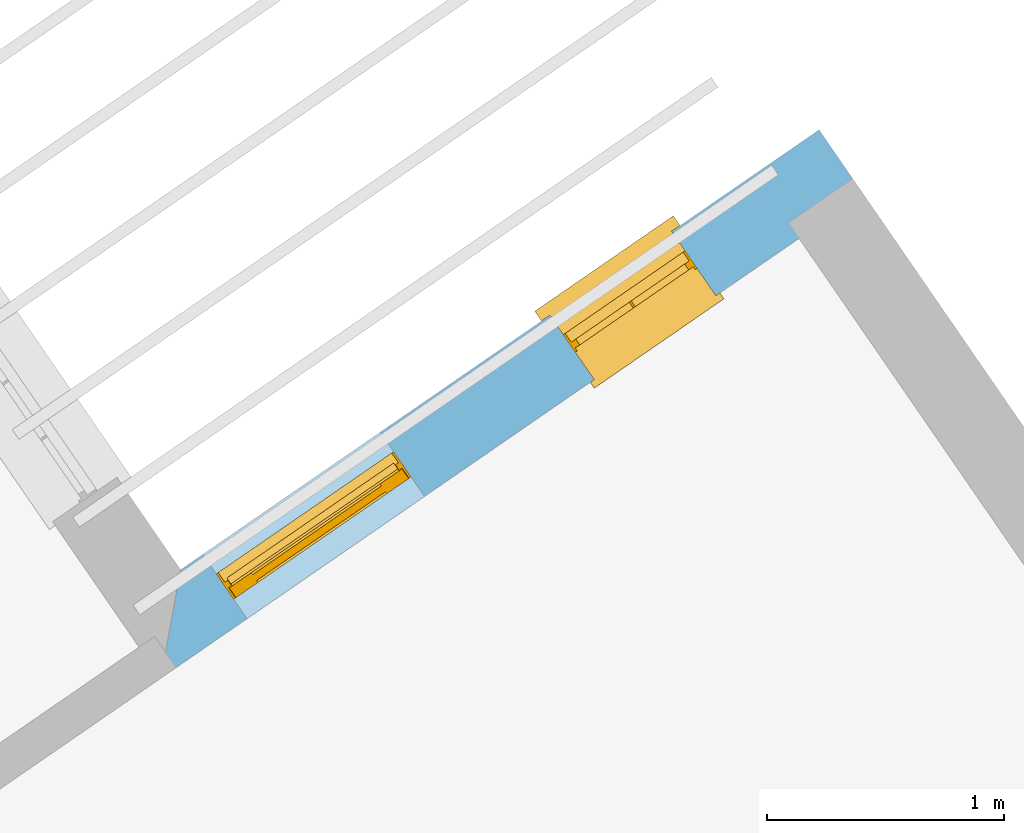
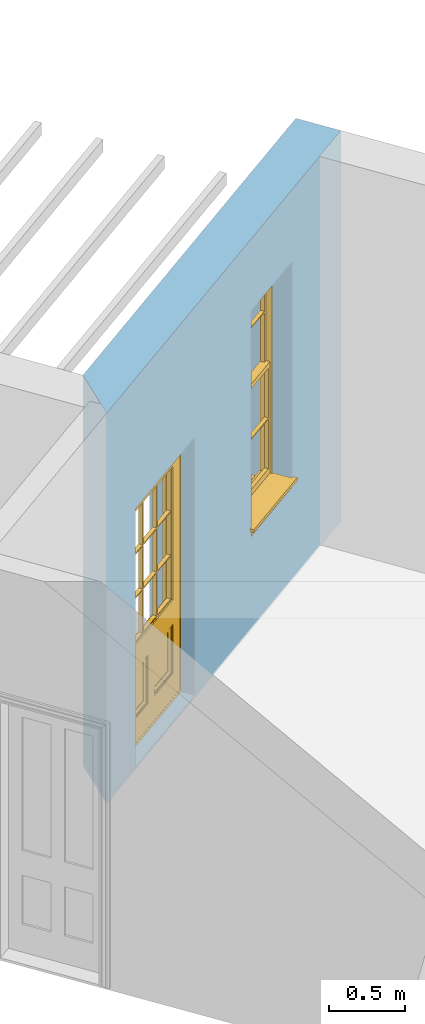
# One storey, part 10 of 12: 1 door, 1 window, 2 openings, plus 1 element that does not belong to this part.
"""IFC2X3 building model written with IfcOpenShell, lengths in metres."""

import ifcopenshell
import ifcopenshell.guid

model = None  # the IFC model being written
_history = None  # IfcOwnerHistory: only IFC2X3 demands one
_inside = {}  # id of a spatial element -> (the spatial element, [elements in it])
_under = {}  # id of a project, library or spatial element -> (it, [spatial elements below it])
_declared = {}  # id of a project -> (the project, [libraries it declares])
_typed = {}  # id of a type object -> (the type object, [elements of that type])
_made_of = {}  # id of a material, layer set ... -> (it, [elements and type objects made of it])


def new_model(schema):
    """Start an empty IFC model of exactly this schema.

    Asked for "IFC4X3", IfcOpenShell would pick the latest addendum, in which some entities
    have other attributes; the version numbers below select the first issue.
    IFC2X3 requires an IfcOwnerHistory on every rooted entity: one is made here for all.
    """
    global model, _history
    if schema == "IFC4X3":
        model = ifcopenshell.file(schema_version=(4, 3, 0, 0))
    else:
        model = ifcopenshell.file(schema=schema)
    _inside.clear()
    _under.clear()
    _declared.clear()
    _typed.clear()
    _made_of.clear()
    _history = None
    if model.schema == "IFC2X3":
        org = make("IfcOrganization", Name="unknown")
        user = make(
            "IfcPersonAndOrganization",
            ThePerson=make("IfcPerson", FamilyName="unknown"),
            TheOrganization=org,
        )
        app = make(
            "IfcApplication",
            ApplicationDeveloper=org,
            Version="unknown",
            ApplicationFullName="unknown",
            ApplicationIdentifier="unknown",
        )
        _history = make(
            "IfcOwnerHistory",
            OwningUser=user,
            OwningApplication=app,
            ChangeAction="ADDED",
            CreationDate=0,
        )
    return model


def make(cls, **values):
    """One entity of the class cls with the attributes given. An attribute that is None is left unset."""
    return model.create_entity(
        cls, **{name: value for name, value in values.items() if value is not None}
    )


def rooted(cls, **values):
    """An entity with a GlobalId (a new one), such as an element, a storey or a relation."""
    return make(cls, GlobalId=ifcopenshell.guid.new(), OwnerHistory=_history, **values)


def si_unit(unit_type, name, prefix=None):
    """IfcSIUnit, for example si_unit("LENGTHUNIT", "METRE", prefix="MILLI")."""
    return make("IfcSIUnit", UnitType=unit_type, Prefix=prefix, Name=name)


def assignment(units):
    """IfcUnitAssignment: the units of a project."""
    return None if units is None else make("IfcUnitAssignment", Units=units)


def point(xyz):
    """IfcCartesianPoint."""
    return None if xyz is None else make("IfcCartesianPoint", Coordinates=xyz)


def direction(xyz):
    """IfcDirection."""
    return None if xyz is None else make("IfcDirection", DirectionRatios=xyz)


def frame(location, z_axis=None, x_axis=None):
    """IfcAxis2Placement3D, a coordinate frame: its origin and axes. An axis left out is left unset."""
    return make(
        "IfcAxis2Placement3D",
        Location=point(location),
        Axis=direction(z_axis),
        RefDirection=direction(x_axis),
    )


def origin():
    """The frame at (0, 0, 0) with its axes left unset."""
    return frame((0.0, 0.0, 0.0))


def place(relative_to, where):
    """IfcLocalPlacement: puts the frame where relative to a parent placement (None: the world)."""
    return make(
        "IfcLocalPlacement", PlacementRelTo=relative_to, RelativePlacement=where
    )


def context(
    kind, dimensions, precision=None, world=None, true_north=None, identifier=None
):
    """IfcGeometricRepresentationContext, for example the 3D "Model" context."""
    return make(
        "IfcGeometricRepresentationContext",
        ContextIdentifier=identifier,
        ContextType=kind,
        CoordinateSpaceDimension=dimensions,
        Precision=precision,
        WorldCoordinateSystem=world,
        TrueNorth=true_north,
    )


def subcontext(parent, identifier, kind, view, scale=None):
    """IfcGeometricRepresentationSubContext, for example "Body" below "Model"."""
    return make(
        "IfcGeometricRepresentationSubContext",
        ContextIdentifier=identifier,
        ContextType=kind,
        ParentContext=parent,
        TargetScale=scale,
        TargetView=view,
    )


def project(units=None, contexts=None):
    """IfcProject with its units and contexts."""
    return rooted(
        "IfcProject",
        Name="project",
        RepresentationContexts=contexts,
        UnitsInContext=assignment(units),
    )


def spatial(cls, under=None, at=None, **own):
    """A site, building, storey or space (cls), placed at a placement, below another one or the project."""
    s = rooted(cls, ObjectPlacement=at, **own)
    if under is not None:
        _under.setdefault(under.id(), (under, []))[1].append(s)
    return s


def polyline(points):
    """IfcPolyline through the points."""
    return make("IfcPolyline", Points=[point(p) for p in points])


def outline(outer, holes=None, kind="AREA"):
    """IfcArbitraryClosedProfileDef: a profile drawn as a closed curve; with holes, ...WithVoids."""
    if holes is None:
        return make("IfcArbitraryClosedProfileDef", ProfileType=kind, OuterCurve=outer)
    return make(
        "IfcArbitraryProfileDefWithVoids",
        ProfileType=kind,
        OuterCurve=outer,
        InnerCurves=holes,
    )


def extrude(swept, where, along, depth):
    """IfcExtrudedAreaSolid: the profile swept, set in the frame where, extruded along a direction by depth."""
    return make(
        "IfcExtrudedAreaSolid",
        SweptArea=swept,
        Position=where,
        ExtrudedDirection=direction(along),
        Depth=depth,
    )


def faces_of(points, faces, orient=None, outer=None):
    """IfcFace entities. A face is a list of loops; a loop is a list of indices into points, from 0.

    orient and outer hold one flag for each loop. By default every Orientation is true, the
    first loop of a face is its IfcFaceOuterBound and the others are IfcFaceBound.
    """
    made = []
    for i, loops in enumerate(faces):
        bounds = []
        for j, loop in enumerate(loops):
            is_outer = j == 0 if outer is None else outer[i][j]
            bounds.append(
                make(
                    "IfcFaceOuterBound" if is_outer else "IfcFaceBound",
                    Bound=make("IfcPolyLoop", Polygon=[points[k] for k in loop]),
                    Orientation=True if orient is None else orient[i][j],
                )
            )
        made.append(make("IfcFace", Bounds=bounds))
    return made


def faceted_brep(points, faces, orient=None, outer=None, voids=None):
    """IfcFacetedBrep: a solid bounded by flat faces; with voids (closed shells), ...WithVoids."""
    shared = [point(p) for p in points]
    hull = make("IfcClosedShell", CfsFaces=faces_of(shared, faces, orient, outer))
    if voids is None:
        return make("IfcFacetedBrep", Outer=hull)
    return make(
        "IfcFacetedBrepWithVoids",
        Outer=hull,
        Voids=[
            make(cls, CfsFaces=faces_of(shared, fs, o, b)) for cls, fs, o, b in voids
        ],
    )


def shape(context_of_items, identifier, shape_type, items):
    """IfcShapeRepresentation: the items that make up one representation, for example the "Body"."""
    return make(
        "IfcShapeRepresentation",
        ContextOfItems=context_of_items,
        RepresentationIdentifier=identifier,
        RepresentationType=shape_type,
        Items=items,
    )


def material(Name=None, Category=None):
    """IfcMaterial."""
    return make("IfcMaterial", Name=Name, Category=Category)


def layer(
    of_material, thickness, ventilated=None, Name=None, Category=None, Priority=None
):
    """IfcMaterialLayer: one layer of a wall or slab, of a material (None: an air gap)."""
    return make(
        "IfcMaterialLayer",
        Material=of_material,
        LayerThickness=thickness,
        IsVentilated=ventilated,
        Name=Name,
        Category=Category,
        Priority=Priority,
    )


def layer_set(layers, Name=None):
    """IfcMaterialLayerSet."""
    return make("IfcMaterialLayerSet", MaterialLayers=layers, LayerSetName=Name)


def layer_usage(for_layer_set, set_direction, sense, offset, extent=None):
    """IfcMaterialLayerSetUsage: how a layer set lies in its element."""
    return make(
        "IfcMaterialLayerSetUsage",
        ForLayerSet=for_layer_set,
        LayerSetDirection=set_direction,
        DirectionSense=sense,
        OffsetFromReferenceLine=offset,
        ReferenceExtent=extent,
    )


def made_of(thing, what):
    """Note that an element or type object is made of a material, layer set ...; save() writes the relation."""
    if what is not None:
        _made_of.setdefault(what.id(), (what, []))[1].append(thing)
    return thing


def element(
    cls,
    number,
    at=None,
    inside=None,
    cuts=None,
    type_object=None,
    material=None,
    context=None,
    identifier="Body",
    shape_type=None,
    held_by="IfcProductDefinitionShape",
    body=None,
    shapes=None,
    **own,
):
    """One element of the class cls, such as IfcWall. Its Tag is "e" and its number.

    at: its placement. inside: the storey or other place that contains it. cuts: it is an
    opening in that element (IfcRelVoidsElement). A single representation is given by context,
    identifier, shape_type and body (its items); several are given by shapes. held_by: the class
    of the entity that holds the representations. save() writes the other relations.
    """
    e = rooted(cls, Tag="e%d" % number, ObjectPlacement=at, **own)
    if body is not None:
        shapes = [shape(context, identifier, shape_type, body)]
    if shapes is not None:
        e.Representation = make(held_by, Representations=shapes)
    if inside is not None:
        _inside.setdefault(inside.id(), (inside, []))[1].append(e)
    if cuts is not None:
        rooted(
            "IfcRelVoidsElement", RelatingBuildingElement=cuts, RelatedOpeningElement=e
        )
    if type_object is not None:
        _typed.setdefault(type_object.id(), (type_object, []))[1].append(e)
    return made_of(e, material)


def fill(opening, filler):
    """IfcRelFillsElement: the door or window that sits in an opening."""
    return rooted(
        "IfcRelFillsElement",
        RelatingOpeningElement=opening,
        RelatedBuildingElement=filler,
    )


def aggregate(whole, parts):
    """IfcRelAggregates: a whole, such as a stair, and the parts it consists of."""
    return rooted("IfcRelAggregates", RelatingObject=whole, RelatedObjects=parts)


def save(model, path):
    """Write the relations noted so far, then the file.

    IfcRelAggregates (storeys below a building ...), IfcRelContainedInSpatialStructure (elements
    in a storey), IfcRelDefinesByType, IfcRelAssociatesMaterial and IfcRelDeclares: one each for
    every whole, place, type object, material and project.
    """
    for whole, parts in _under.values():
        aggregate(whole, parts)
    for where, things in _inside.values():
        rooted(
            "IfcRelContainedInSpatialStructure",
            RelatedElements=things,
            RelatingStructure=where,
        )
    for kind, things in _typed.values():
        rooted("IfcRelDefinesByType", RelatedObjects=things, RelatingType=kind)
    for what, things in _made_of.values():
        rooted("IfcRelAssociatesMaterial", RelatedObjects=things, RelatingMaterial=what)
    for by, libraries in _declared.values():
        rooted("IfcRelDeclares", RelatingContext=by, RelatedDefinitions=libraries)
    model.write(path)


model = new_model("IFC2X3")

# Units and contexts
model_context = context("Model", 3, world=origin())
body_context = subcontext(model_context, "Body", "Model", "MODEL_VIEW")
ifc_project = project(units=[si_unit("PLANEANGLEUNIT", "RADIAN"), si_unit("MASSUNIT", "GRAM", prefix="KILO"), si_unit("FORCEUNIT", "NEWTON", prefix="KILO"), si_unit("LENGTHUNIT", "METRE")], contexts=[model_context])

# Site, building, storey
site_placement = place(None, origin())
site = spatial("IfcSite", under=ifc_project, at=site_placement, CompositionType="ELEMENT")
building_placement = place(None, origin())
building = spatial("IfcBuilding", under=site, at=building_placement, Name="Building plot-7", CompositionType="ELEMENT")
storey_placement = place(None, frame((0.0, 0.0, 8.0)))
storey = spatial("IfcBuildingStorey", under=building, at=storey_placement, Name="Floor 1", CompositionType="ELEMENT", Elevation=8.0)

# Wall, openings, window, door
ifc_material = material(Name="Masonry")
ifc_layer = layer(ifc_material, 0.33, ventilated=False)
ifc_layer_set = layer_set([ifc_layer], Name="My Wall")
ifc_layer_usage = layer_usage(ifc_layer_set, "AXIS2", "NEGATIVE", 0.08)
wall_placement = place(storey_placement, origin())
wall = element("IfcWallStandardCase", 1, at=wall_placement, inside=storey, material=ifc_layer_usage, Name="exterior", context=body_context, shape_type="SweptSolid", body=[
    extrude(outline(polyline([(91.0785503599906, 69.5821159322684), (90.8913181093014, 69.853858612578), (88.1944908209502, 67.9957292883857), (88.1099803913297, 67.5367543573869), (91.0785503599906, 69.5821159322684)])), origin(), (0.0, 0.0, 1.0), 3.15),
])
opening_1_placement = place(storey_placement, frame((0.0, 0.0, 0.75)))
opening_1 = element("IfcOpeningElement", 2, at=opening_1_placement, cuts=wall, Name="Opening", ObjectType="Opening", context=body_context, shape_type="SweptSolid", body=[
    extrude(outline(polyline([(90.2685777039389, 69.4247869350695), (89.7539135366858, 69.0701803996734), (89.9411457873749, 68.7984377193637), (90.4558099546281, 69.1530442547599), (90.2685777039389, 69.4247869350695)])), origin(), (0.0, 0.0, 1.0), 1.82),
])
opening_2_placement = place(storey_placement, frame((0.0, 0.0, 0.0199999999999996)))
opening_2 = element("IfcOpeningElement", 3, at=opening_2_placement, cuts=wall, Name="Opening", ObjectType="Opening", context=body_context, shape_type="SweptSolid", body=[
    extrude(outline(polyline([(89.037507489897, 68.5765725630437), (88.2881564623765, 68.0602654475069), (88.4753887130656, 67.7885227671973), (89.2247397405862, 68.3048298827341), (89.037507489897, 68.5765725630437)])), origin(), (0.0, 0.0, 1.0), 2.08),
])
window_placement = place(storey_placement, frame((90.4104203180974, 69.2189212681683, 0.75), z_axis=(0.0, 0.0, 1.0), x_axis=(-0.514664167253116, -0.354606535396158, 0.0)))
window = element("IfcWindow", 4, at=window_placement, inside=storey, Name="bedroom outside window", OverallHeight=1.82, OverallWidth=0.625, context=body_context, shape_type="Brep", held_by="IfcProductRepresentation", body=[
    faceted_brep([(0.033125, -0.105, 0.975209), (0.01, -0.105, 0.975209), (0.033125, -0.105, 1.376042), (0.591875, -0.105, 0.975209), (0.591875, -0.105, 1.376042), (0.615, -0.105, 0.975209), (0.591875, -0.105, 1.386042), (0.591875, -0.105, 1.786875), (0.615, -0.105, 1.81), (0.033125, -0.105, 1.786875), (0.033125, -0.105, 1.386042), (0.01, -0.105, 1.81), (0.591875, -0.135, 1.376042), (0.591875, -0.135, 0.975209), (0.615, -0.135, 0.937083), (0.033125, -0.135, 1.786875), (0.01, -0.135, 1.81), (0.033125, -0.135, 1.386042), (0.01, -0.135, 0.937083), (0.033125, -0.135, 0.975209), (0.033125, -0.135, 1.376042), (0.591875, -0.135, 1.786875), (0.591875, -0.135, 1.386042), (0.615, -0.135, 1.81), (0.033125, -0.105, 0.937083), (0.01, -0.105, 0.937083), (0.033125, -0.105, 0.53625), (0.591875, -0.105, 0.937083), (0.591875, -0.105, 0.53625), (0.615, -0.105, 0.937083), (0.591875, -0.105, 0.52625), (0.591875, -0.105, 0.125417), (0.615, -0.105, 0.077167), (0.033125, -0.105, 0.125417), (0.033125, -0.105, 0.52625), (0.01, -0.105, 0.077167), (-0.0425, -0.25, 0.01), (-0.0425, -0.3, 0.001667), (0.0, -0.25, 0.01), (0.6675, -0.25, 0.01), (0.625, -0.25, 0.01), (0.6675, -0.3, 0.001667), (-0.02, 0.08, 0.077167), (0.0, 0.08, 0.077167), (-0.02, 0.11, 0.077167), (0.0, -0.06, 0.077167), (0.01, -0.06, 0.077167), (0.625, -0.06, 0.077167), (0.625, 0.08, 0.077167), (0.615, -0.06, 0.077167), (0.645, 0.08, 0.077167), (0.645, 0.11, 0.077167), (0.01, -0.075, 0.975209), (0.615, -0.075, 0.975209), (0.591875, -0.075, 0.125417), (0.591875, -0.075, 0.52625), (0.615, -0.075, 0.077167), (0.591875, -0.075, 0.53625), (0.591875, -0.075, 0.937083), (0.033125, -0.075, 0.125417), (0.01, -0.075, 0.077167), (0.033125, -0.075, 0.52625), (0.033125, -0.075, 0.937083), (0.033125, -0.075, 0.53625), (-0.02, 0.08, 0.052167), (-0.02, 0.11, 0.052167), (0.645, 0.11, 0.052167), (0.645, 0.08, 0.052167), (0.625, 0.08, 0.052167), (0.0, 0.08, 0.052167), (0.625, -0.15, 0.026667), (0.0, -0.15, 0.026667), (-0.0425, -0.3, -0.123333), (0.6675, -0.3, -0.123333), (-0.0425, -0.25, -0.123333), (0.6675, -0.25, -0.123333), (0.01, -0.06, 1.81), (0.615, -0.06, 1.81), (0.0, -0.06, 1.82), (0.625, -0.06, 1.82), (0.01, -0.15, 0.077167), (0.615, -0.15, 0.077167), (0.3175, -0.075, 0.53625), (0.3175, -0.105, 0.53625), (0.3175, -0.075, 0.52625), (0.3175, -0.075, 0.125417), (0.3075, -0.075, 0.125417), (0.3075, -0.075, 0.52625), (0.3075, -0.075, 0.53625), (0.3175, -0.075, 0.937083), (0.3075, -0.075, 0.937083), (0.3075, -0.105, 0.52625), (0.3075, -0.105, 0.125417), (0.3175, -0.105, 0.125417), (0.3175, -0.105, 0.52625), (0.3075, -0.105, 0.53625), (0.3075, -0.105, 0.937083), (0.3175, -0.105, 0.937083), (0.3075, -0.135, 1.386042), (0.3075, -0.135, 1.376042), (0.3175, -0.135, 1.376042), (0.3075, -0.135, 0.975209), (0.3175, -0.135, 0.975209), (0.3175, -0.135, 1.786875), (0.3075, -0.135, 1.786875), (0.3175, -0.135, 1.386042), (0.3175, -0.105, 1.386042), (0.3175, -0.105, 1.376042), (0.3075, -0.105, 1.386042), (0.3075, -0.105, 1.786875), (0.3175, -0.105, 1.786875), (0.3075, -0.105, 1.376042), (0.3175, -0.105, 0.975209), (0.3075, -0.105, 0.975209), (0.625, -0.15, 1.82), (0.615, -0.15, 1.81), (0.01, -0.15, 1.81), (0.0, -0.15, 1.82), (0.625, -0.25, 0.0), (0.0, -0.25, 0.0), (0.625, 0.08, 0.0), (0.0, 0.08, 0.0)], [[[0, 1, 2]], [[3, 4, 5]], [[6, 7, 8]], [[9, 10, 11]], [[12, 13, 14]], [[15, 16, 17]], [[18, 19, 20]], [[21, 22, 23]], [[24, 25, 26]], [[27, 28, 29]], [[30, 31, 32]], [[33, 34, 35]], [[14, 27, 29]], [[25, 24, 18]], [[36, 37, 38]], [[39, 40, 41]], [[42, 43, 44]], [[45, 46, 43]], [[47, 48, 49]], [[50, 51, 48]], [[1, 0, 52]], [[5, 53, 3]], [[54, 55, 56]], [[57, 58, 53]], [[59, 60, 61]], [[62, 63, 52]], [[48, 43, 46, 49]], [[51, 44, 43, 48]], [[64, 42, 44, 65]], [[65, 44, 51, 66]], [[66, 51, 50, 67]], [[65, 66, 68, 69]], [[60, 56, 49, 46]], [[70, 71, 38, 40]], [[37, 41, 40, 38]], [[37, 72, 73, 41]], [[74, 75, 73, 72]], [[8, 11, 76, 77]], [[76, 78, 79, 77]], [[32, 35, 80, 81]], [[81, 80, 71, 70]], [[28, 57, 82, 83]], [[84, 85, 86, 87]], [[88, 87, 61, 63]], [[89, 82, 88, 90]], [[84, 82, 57, 55]], [[91, 87, 86, 92]], [[34, 61, 87, 91]], [[93, 85, 84, 94]], [[95, 88, 63, 26]], [[96, 90, 88, 95]], [[83, 82, 89, 97]], [[94, 84, 55, 30]], [[94, 30, 28, 83]], [[94, 91, 92, 93]], [[95, 26, 34, 91]], [[97, 96, 95, 83]], [[98, 17, 20, 99]], [[100, 99, 101, 102]], [[103, 104, 98, 105]], [[100, 12, 22, 105]], [[106, 6, 4, 107]], [[106, 108, 109, 110]], [[111, 2, 10, 108]], [[112, 113, 111, 107]], [[99, 111, 113, 101]], [[20, 2, 111, 99]], [[102, 112, 107, 100]], [[98, 108, 10, 17]], [[104, 109, 108, 98]], [[105, 106, 110, 103]], [[22, 6, 106, 105]], [[100, 107, 4, 12]], [[82, 84, 87, 88]], [[83, 95, 91, 94]], [[99, 100, 105, 98]], [[107, 111, 108, 106]], [[92, 86, 59, 33]], [[15, 9, 109, 104]], [[103, 110, 7, 21]], [[31, 54, 85, 93]], [[36, 74, 72, 37]], [[39, 41, 73, 75]], [[18, 14, 102, 101]], [[23, 16, 104, 103]], [[85, 56, 60, 86]], [[52, 53, 89, 90]], [[53, 52, 113, 112]], [[11, 8, 110, 109]], [[14, 18, 96, 97]], [[2, 1, 11, 10]], [[8, 5, 4, 6]], [[57, 53, 56, 55]], [[60, 52, 63, 61]], [[26, 25, 35, 34]], [[32, 29, 28, 30]], [[14, 23, 22, 12]], [[18, 20, 17, 16]], [[19, 0, 2, 20]], [[17, 10, 9, 15]], [[12, 4, 3, 13]], [[21, 7, 6, 22]], [[27, 58, 57, 28]], [[30, 55, 54, 31]], [[33, 59, 61, 34]], [[26, 63, 62, 24]], [[5, 8, 77, 53]], [[76, 11, 1, 52]], [[46, 45, 78, 76]], [[49, 77, 79, 47]], [[70, 114, 115, 81]], [[71, 80, 116, 117]], [[19, 101, 113, 0]], [[102, 13, 3, 112]], [[90, 96, 24, 62]], [[29, 32, 81, 14]], [[80, 35, 25, 18]], [[60, 46, 76, 52]], [[77, 49, 56, 53]], [[23, 14, 81, 115]], [[16, 116, 80, 18]], [[92, 33, 35]], [[32, 31, 93]], [[32, 93, 92, 35]], [[14, 13, 102]], [[101, 19, 18]], [[103, 21, 23]], [[16, 15, 104]], [[109, 9, 11]], [[8, 7, 110]], [[23, 115, 116, 16]], [[114, 117, 116, 115]], [[90, 62, 52]], [[58, 89, 53]], [[27, 97, 89, 58]], [[85, 54, 56]], [[60, 59, 86]], [[97, 27, 14]], [[18, 24, 96]], [[52, 0, 113]], [[112, 3, 53]], [[79, 78, 117, 114]], [[78, 45, 71, 117]], [[114, 70, 47, 79]], [[118, 75, 74, 119]], [[68, 66, 67]], [[48, 68, 67, 50]], [[69, 64, 65]], [[42, 64, 69, 43]], [[69, 68, 120, 121]], [[70, 68, 48, 47]], [[118, 120, 68, 70]], [[43, 69, 71, 45]], [[69, 121, 119, 71]], [[120, 118, 119, 121]], [[38, 119, 74, 36]], [[71, 119, 38]], [[39, 75, 118, 40]], [[40, 118, 70]]]),
])
fill(opening_1, window)
door_placement = place(storey_placement, frame((89.1793501040555, 68.3707068961425, 0.0199999999999996), z_axis=(0.0, 0.0, 1.0), x_axis=(-0.749351027520532, -0.51630711553679, 0.0)))
door = element("IfcDoor", 5, at=door_placement, inside=storey, Name="bedroom outside door", OverallHeight=2.08, OverallWidth=0.91, context=body_context, shape_type="Brep", held_by="IfcProductRepresentation", body=[
    faceted_brep([(0.545, -0.055, 0.265), (0.745, -0.055, 0.265), (0.745, -0.05, 0.265), (0.545, -0.05, 0.265), (0.745, -0.05, 0.58), (0.545, -0.05, 0.58), (0.545, -0.055, 0.58), (0.515, -0.06, 0.235), (0.775, -0.06, 0.235), (0.745, -0.055, 0.58), (0.515, -0.06, 0.61), (0.515, -0.065, 0.235), (0.775, -0.065, 0.235), (0.775, -0.06, 0.61), (0.515, -0.065, 0.61), (0.785, -0.065, 0.225), (0.505, -0.065, 0.225), (0.775, -0.065, 0.61), (0.505, -0.065, 0.62), (0.785, -0.065, 0.62), (0.505, -0.07, 0.225), (0.785, -0.07, 0.225), (0.505, -0.07, 0.62), (0.785, -0.07, 0.62), (0.883, -0.07, 0.075), (0.898, -0.07, 0.075), (0.405, -0.07, 0.62), (0.405, -0.07, 0.225), (0.027, -0.07, 0.075), (0.785, -0.07, 0.82), (0.125, -0.07, 0.82), (0.405, -0.065, 0.62), (0.405, -0.065, 0.225), (0.898, -0.07, 2.068), (0.027, -0.08, 0.075), (0.883, -0.08, 0.075), (0.125, -0.07, 0.225), (0.012, -0.07, 0.075), (0.785, -0.06, 0.82), (0.125, -0.06, 0.82), (0.125, -0.07, 0.62), (0.125, -0.065, 0.62), (0.395, -0.065, 0.61), (0.395, -0.065, 0.235), (0.125, -0.065, 0.225), (0.785, -0.07, 1.895), (0.027, -0.11, 0.045), (0.883, -0.11, 0.045), (0.558333, -0.06, 0.83), (0.351667, -0.06, 0.83), (0.125, -0.07, 1.895), (0.125, -0.06, 1.895), (0.785, -0.06, 1.895), (0.012, -0.07, 2.068), (0.135, -0.065, 0.61), (0.395, -0.06, 0.61), (0.395, -0.06, 0.235), (0.135, -0.065, 0.235), (0.027, -0.11, 0.027), (0.883, -0.11, 0.027), (0.568333, -0.06, 0.83), (0.558333, -0.03, 0.83), (0.351667, -0.03, 0.83), (0.341667, -0.06, 0.83), (0.135, -0.06, 1.185), (0.135, -0.06, 1.53), (0.775, -0.06, 1.53), (0.775, -0.06, 1.185), (0.135, -0.06, 0.61), (0.365, -0.055, 0.58), (0.365, -0.055, 0.265), (0.135, -0.06, 0.235), (0.568333, -0.06, 1.175), (0.558333, -0.06, 1.175), (0.775, -0.06, 0.83), (0.558333, -0.03, 1.175), (0.785, -0.03, 0.82), (0.125, -0.03, 0.82), (0.351667, -0.03, 1.175), (0.351667, -0.06, 1.175), (0.341667, -0.06, 1.175), (0.135, -0.06, 0.83), (0.135, -0.06, 1.175), (0.135, -0.03, 1.185), (0.135, -0.03, 1.53), (0.135, -0.06, 1.54), (0.351667, -0.06, 1.885), (0.558333, -0.06, 1.885), (0.775, -0.03, 1.53), (0.775, -0.03, 1.185), (0.775, -0.06, 1.175), (0.775, -0.06, 1.54), (0.165, -0.055, 0.58), (0.365, -0.05, 0.58), (0.365, -0.05, 0.265), (0.165, -0.055, 0.265), (0.568333, -0.03, 0.83), (0.568333, -0.03, 1.175), (0.568333, -0.06, 1.185), (0.558333, -0.06, 1.185), (0.775, -0.03, 0.83), (0.785, -0.02, 0.82), (0.125, -0.02, 0.82), (0.341667, -0.03, 0.83), (0.341667, -0.03, 1.175), (0.351667, -0.06, 1.185), (0.341667, -0.06, 1.185), (0.135, -0.03, 0.83), (0.341667, -0.03, 1.185), (0.125, -0.03, 1.895), (0.341667, -0.03, 1.53), (0.341667, -0.06, 1.53), (0.135, -0.06, 1.885), (0.341667, -0.06, 1.54), (0.341667, -0.06, 1.885), (0.558333, -0.03, 1.885), (0.351667, -0.03, 1.885), (0.568333, -0.06, 1.885), (0.785, -0.03, 1.895), (0.568333, -0.03, 1.185), (0.568333, -0.06, 1.53), (0.568333, -0.03, 1.53), (0.568333, -0.06, 1.54), (0.775, -0.06, 1.885), (0.165, -0.05, 0.58), (0.165, -0.05, 0.265), (0.775, -0.03, 1.175), (0.558333, -0.06, 1.53), (0.351667, -0.03, 1.185), (0.558333, -0.03, 1.185), (0.505, -0.02, 0.62), (0.405, -0.02, 0.62), (0.125, -0.02, 1.895), (0.785, -0.02, 1.895), (0.351667, -0.06, 1.53), (0.135, -0.03, 1.175), (0.135, -0.03, 1.54), (0.341667, -0.03, 1.54), (0.135, -0.03, 1.885), (0.351667, -0.06, 1.54), (0.558333, -0.03, 1.54), (0.558333, -0.06, 1.54), (0.351667, -0.03, 1.54), (0.775, -0.03, 1.54), (0.568333, -0.03, 1.54), (0.775, -0.03, 1.885), (0.558333, -0.03, 1.53), (0.405, -0.02, 0.225), (0.505, -0.02, 0.225), (0.125, -0.02, 0.62), (0.785, -0.02, 0.62), (0.012, -0.02, 2.068), (0.898, -0.02, 2.068), (0.351667, -0.03, 1.53), (0.341667, -0.03, 1.885), (0.568333, -0.03, 1.885), (0.405, -0.025, 0.225), (0.405, -0.025, 0.62), (0.505, -0.025, 0.62), (0.505, -0.025, 0.225), (0.898, -0.02, 0.027), (0.012, -0.02, 0.027), (0.125, -0.025, 0.62), (0.785, -0.025, 0.62), (0.395, -0.025, 0.235), (0.395, -0.025, 0.61), (0.125, -0.02, 0.225), (0.125, -0.025, 0.225), (0.515, -0.025, 0.61), (0.515, -0.025, 0.235), (0.785, -0.02, 0.225), (0.785, -0.025, 0.225), (0.135, -0.025, 0.61), (0.775, -0.025, 0.61), (0.135, -0.025, 0.235), (0.395, -0.03, 0.235), (0.395, -0.03, 0.61), (0.515, -0.03, 0.61), (0.515, -0.03, 0.235), (0.775, -0.025, 0.235), (0.135, -0.03, 0.61), (0.775, -0.03, 0.61), (0.135, -0.03, 0.235), (0.365, -0.035, 0.265), (0.365, -0.035, 0.58), (0.545, -0.035, 0.58), (0.545, -0.035, 0.265), (0.775, -0.03, 0.235), (0.165, -0.035, 0.58), (0.745, -0.035, 0.58), (0.165, -0.035, 0.265), (0.365, -0.04, 0.58), (0.365, -0.04, 0.265), (0.545, -0.04, 0.58), (0.545, -0.04, 0.265), (0.745, -0.035, 0.265), (0.165, -0.04, 0.58), (0.745, -0.04, 0.58), (0.165, -0.04, 0.265), (0.745, -0.04, 0.265), (0.885, -0.072, 0.025), (0.025, -0.072, 0.025), (0.025, -0.1, 0.025), (0.885, -0.1, 0.025), (0.9, -0.02, 0.025), (0.01, -0.02, 0.025), (0.9, -0.072, 0.025), (0.91, -0.02, 0.0), (0.0, -0.02, 0.0), (0.01, -0.072, 0.025), (0.9, -0.072, 2.07), (0.9, -0.02, 2.07), (0.885, -0.072, 2.055), (0.91, -0.02, 2.08), (0.01, -0.02, 2.07), (0.0, -0.02, 2.08), (0.01, -0.072, 2.07), (0.025, -0.072, 2.055), (0.0, -0.15, 2.08), (0.91, -0.15, 2.08), (0.01, -0.15, 2.07), (0.9, -0.15, 2.07), (0.01, -0.1, 2.07), (0.9, -0.1, 2.07), (0.0, -0.15, 0.0), (0.91, -0.15, 0.0), (0.01, -0.15, 0.025), (0.9, -0.15, 0.025), (0.01, -0.1, 0.025), (0.025, -0.1, 2.055), (0.9, -0.1, 0.025), (0.885, -0.1, 2.055), (0.898, -0.07, 0.027), (0.012, -0.07, 0.027), (0.883, -0.07, 0.027), (0.027, -0.07, 0.027)], [[[0, 1, 2, 3]], [[2, 4, 5, 3]], [[0, 3, 5, 6]], [[1, 0, 7, 8]], [[9, 4, 2, 1]], [[9, 6, 5, 4]], [[0, 6, 10, 7]], [[8, 7, 11, 12]], [[8, 13, 9, 1]], [[13, 10, 6, 9]], [[7, 10, 14, 11]], [[15, 12, 11, 16]], [[12, 17, 13, 8]], [[17, 14, 10, 13]], [[18, 16, 11, 14]], [[15, 19, 17, 12]], [[15, 16, 20, 21]], [[14, 17, 19, 18]], [[16, 18, 22, 20]], [[21, 23, 19, 15]], [[24, 25, 21, 20]], [[23, 22, 18, 19]], [[20, 22, 26, 27]], [[23, 21, 25]], [[28, 24, 20, 27]], [[22, 23, 29]], [[29, 30, 26, 22]], [[27, 26, 31, 32]], [[23, 25, 33, 29]], [[34, 35, 24, 28]], [[28, 27, 36, 37]], [[38, 39, 30, 29]], [[26, 30, 40]], [[26, 40, 41, 31]], [[42, 43, 32, 31]], [[32, 44, 36, 27]], [[33, 45, 29]], [[46, 47, 35, 34]], [[36, 40, 37]], [[39, 38, 48, 49]], [[50, 30, 39, 51]], [[29, 45, 52, 38]], [[53, 37, 40, 30]], [[44, 41, 40, 36]], [[31, 41, 54, 42]], [[43, 42, 55, 56]], [[57, 44, 32, 43]], [[50, 45, 33, 53]], [[47, 46, 58, 59]], [[60, 48, 38]], [[49, 48, 61, 62]], [[49, 63, 39]], [[50, 53, 30]], [[51, 39, 64, 65]], [[45, 50, 51, 52]], [[66, 67, 38, 52]], [[57, 54, 41, 44]], [[42, 54, 68, 55]], [[56, 55, 69, 70]], [[56, 71, 57, 43]], [[60, 72, 73, 48]], [[60, 38, 74]], [[48, 73, 75, 61]], [[76, 77, 62, 61]], [[62, 78, 79, 49]], [[49, 79, 80, 63]], [[63, 81, 39]], [[82, 64, 39]], [[65, 64, 83, 84]], [[85, 51, 65]], [[52, 51, 86, 87]], [[88, 89, 67, 66]], [[90, 38, 67]], [[91, 66, 52]], [[71, 68, 54, 57]], [[55, 68, 92, 69]], [[69, 93, 94, 70]], [[70, 95, 71, 56]], [[96, 97, 72, 60]], [[73, 72, 98, 99]], [[74, 38, 90]], [[100, 96, 60, 74]], [[75, 73, 79, 78]], [[61, 75, 97, 96]], [[101, 102, 77, 76]], [[77, 103, 62]], [[96, 76, 61]], [[103, 104, 78, 62]], [[80, 79, 105, 106]], [[63, 80, 104, 103]], [[81, 63, 103, 107]], [[81, 82, 39]], [[106, 64, 82, 80]], [[106, 108, 83, 64]], [[84, 83, 77, 109]], [[110, 111, 65, 84]], [[112, 51, 85]], [[113, 85, 65, 111]], [[114, 86, 51]], [[115, 87, 86, 116]], [[117, 52, 87]], [[118, 76, 89, 88]], [[119, 98, 67, 89]], [[120, 121, 88, 66]], [[67, 98, 72, 90]], [[91, 122, 120, 66]], [[91, 52, 123]], [[95, 92, 68, 71]], [[69, 92, 124, 93]], [[94, 93, 124, 125]], [[94, 125, 95, 70]], [[72, 97, 126, 90]], [[127, 99, 98, 120]], [[99, 105, 79, 73]], [[74, 90, 126, 100]], [[96, 100, 76]], [[128, 129, 75, 78]], [[97, 75, 129, 119]], [[130, 131, 102, 101]], [[109, 77, 102, 132]], [[133, 101, 76, 118]], [[77, 107, 103]], [[78, 104, 108, 128]], [[111, 106, 105, 134]], [[104, 80, 82, 135]], [[107, 135, 82, 81]], [[110, 108, 106, 111]], [[104, 135, 83, 108]], [[83, 135, 77]], [[136, 84, 109]], [[110, 84, 136, 137]], [[114, 51, 112]], [[85, 136, 138, 112]], [[113, 137, 136, 85]], [[111, 134, 139, 113]], [[86, 114, 113, 139]], [[140, 141, 87, 115]], [[139, 142, 116, 86]], [[109, 118, 115, 116]], [[117, 123, 52]], [[117, 87, 141, 122]], [[126, 89, 76]], [[143, 118, 88]], [[120, 98, 119, 121]], [[119, 89, 126, 97]], [[144, 143, 88, 121]], [[144, 122, 91, 143]], [[127, 120, 122, 141]], [[143, 91, 123, 145]], [[124, 92, 95, 125]], [[146, 129, 99, 127]], [[99, 129, 128, 105]], [[100, 126, 76]], [[121, 119, 129, 146]], [[147, 131, 130, 148]], [[131, 149, 102]], [[130, 101, 150]], [[102, 151, 132]], [[118, 109, 132, 133]], [[101, 133, 152]], [[107, 77, 135]], [[153, 128, 108, 110]], [[134, 105, 128, 153]], [[109, 138, 136]], [[153, 110, 137, 142]], [[154, 114, 112, 138]], [[137, 113, 114, 154]], [[141, 139, 134, 127]], [[141, 140, 142, 139]], [[144, 140, 115, 155]], [[142, 137, 154, 116]], [[155, 115, 118]], [[116, 154, 109]], [[117, 155, 145, 123]], [[122, 144, 155, 117]], [[143, 145, 118]], [[121, 146, 140, 144]], [[146, 127, 134, 153]], [[156, 157, 131, 147]], [[148, 130, 158, 159]], [[148, 160, 161, 147]], [[157, 162, 149, 131]], [[161, 151, 102, 149]], [[101, 152, 160, 150]], [[163, 158, 130, 150]], [[151, 152, 133, 132]], [[154, 138, 109]], [[142, 140, 146, 153]], [[145, 155, 118]], [[157, 156, 164, 165]], [[147, 166, 167, 156]], [[168, 169, 159, 158]], [[170, 148, 159, 171]], [[148, 170, 160]], [[166, 147, 161]], [[172, 162, 157, 165]], [[166, 149, 162, 167]], [[166, 161, 149]], [[150, 160, 170]], [[163, 173, 168, 158]], [[171, 163, 150, 170]], [[174, 164, 156, 167]], [[175, 176, 165, 164]], [[169, 168, 177, 178]], [[171, 159, 169, 179]], [[167, 162, 172, 174]], [[176, 180, 172, 165]], [[179, 173, 163, 171]], [[181, 177, 168, 173]], [[164, 174, 182, 175]], [[183, 184, 176, 175]], [[178, 177, 185, 186]], [[179, 169, 178, 187]], [[174, 172, 180, 182]], [[184, 188, 180, 176]], [[187, 181, 173, 179]], [[189, 185, 177, 181]], [[175, 182, 190, 183]], [[191, 184, 183, 192]], [[185, 193, 194, 186]], [[187, 178, 186, 195]], [[182, 180, 188, 190]], [[191, 196, 188, 184]], [[195, 189, 181, 187]], [[197, 193, 185, 189]], [[183, 190, 198, 192]], [[198, 196, 191, 192]], [[194, 193, 197, 199]], [[195, 186, 194, 199]], [[188, 196, 198, 190]], [[197, 189, 195, 199]], [[200, 201, 202, 203]], [[201, 200, 204, 205]], [[206, 204, 200]], [[204, 207, 208, 205]], [[209, 201, 205]], [[210, 211, 204, 206]], [[206, 200, 212, 210]], [[211, 213, 207, 204]], [[214, 205, 208, 215]], [[216, 217, 201, 209]], [[205, 214, 216, 209]], [[216, 214, 211, 210]], [[210, 212, 217, 216]], [[214, 215, 213, 211]], [[218, 219, 213, 215]], [[219, 218, 220, 221]], [[221, 220, 222, 223]], [[215, 208, 224, 218]], [[225, 224, 208, 207]], [[224, 226, 220, 218]], [[224, 225, 227, 226]], [[219, 225, 207, 213]], [[228, 222, 220, 226]], [[219, 221, 227, 225]], [[226, 227, 203, 202]], [[202, 229, 222, 228]], [[228, 226, 202]], [[227, 221, 223, 230]], [[230, 203, 227]], [[217, 229, 202, 201]], [[231, 223, 222, 229]], [[230, 223, 231, 203]], [[231, 229, 217, 212]], [[212, 200, 203, 231]], [[33, 152, 151, 53]], [[25, 160, 152, 33]], [[161, 37, 53, 151]], [[232, 160, 25]], [[161, 233, 37]], [[160, 232, 234]], [[24, 234, 232, 25]], [[233, 161, 235]], [[37, 233, 235, 28]], [[161, 160, 234, 235]], [[35, 47, 234, 24]], [[28, 235, 46, 34]], [[58, 235, 234, 59]], [[59, 234, 47]], [[58, 46, 235]]]),
])
fill(opening_2, door)

save(model, "model.ifc")
